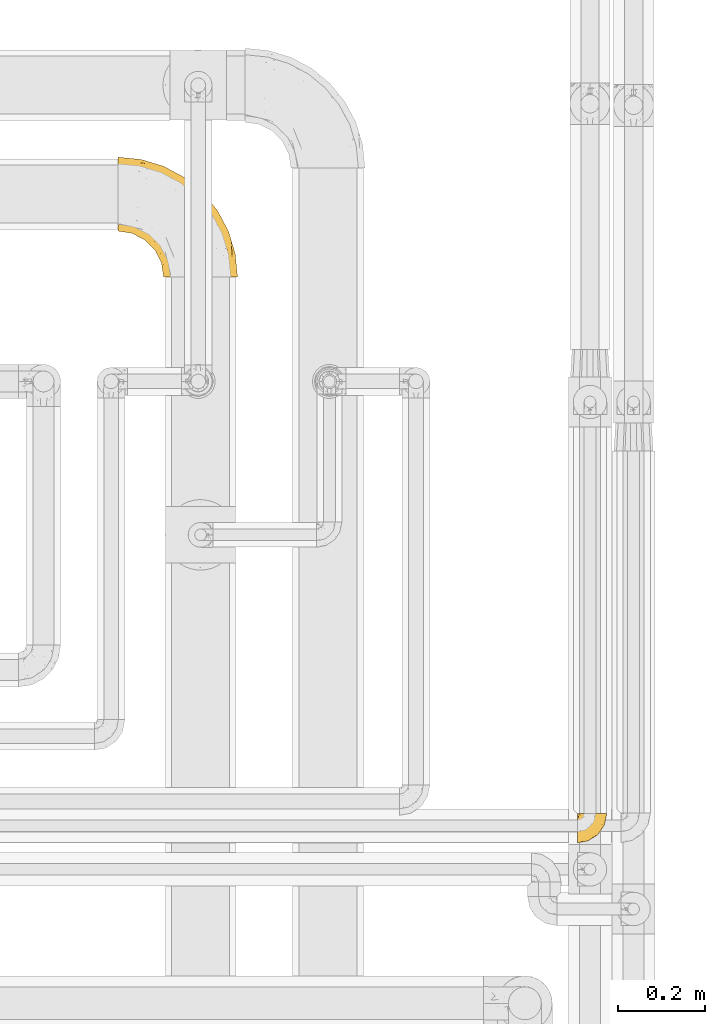
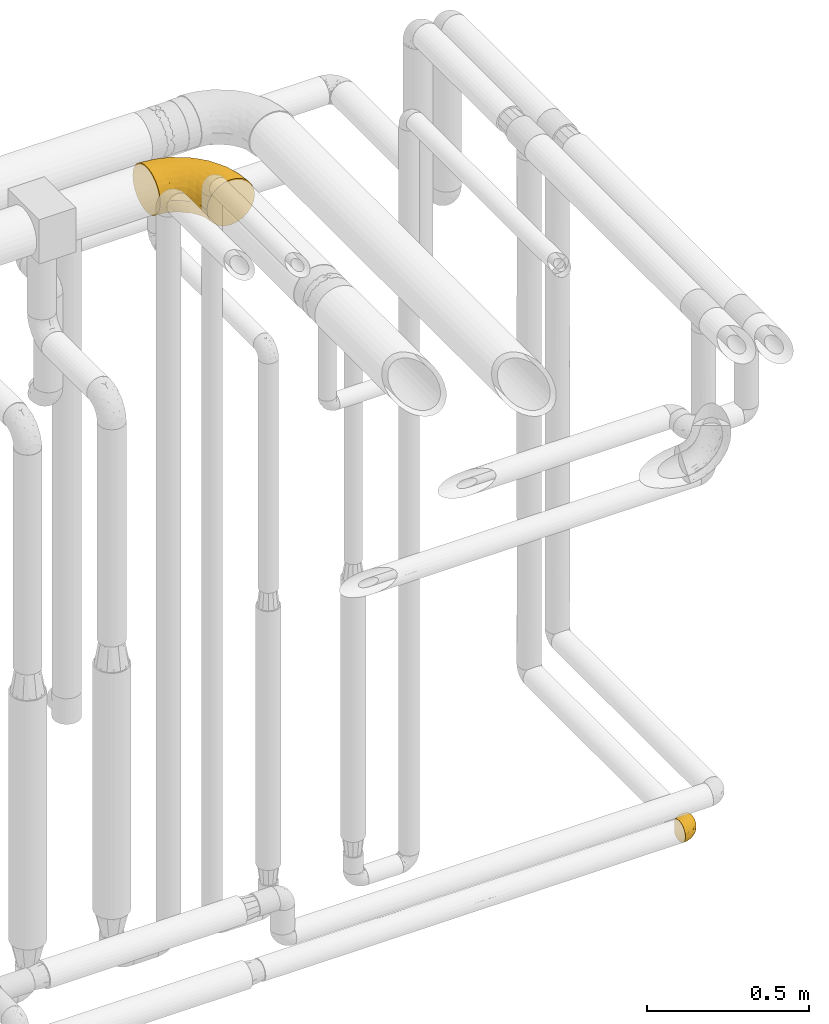
# One storey, part 500 of 827: 2 coverings.
"""IFC2X3 building model written with IfcOpenShell, lengths in millimetres."""

from ifc_helpers import new_model, entity, si_unit, converted_unit, derived_unit, direction, frame, origin, place, context, subcontext, project, spatial, faceted_brep, element, save


model = new_model("IFC2X3")

# Units and contexts
model_context = context("Model", 3, precision=0.01, world=origin(), true_north=direction((6.12303176911189e-17, 1.0)))
body_context = subcontext(model_context, "Body", "Model", "MODEL_VIEW")
ifc_project = project(units=[si_unit("LENGTHUNIT", "METRE", prefix="MILLI"), si_unit("AREAUNIT", "SQUARE_METRE"), si_unit("VOLUMEUNIT", "CUBIC_METRE"), converted_unit("PLANEANGLEUNIT", "DEGREE", entity("IfcRatioMeasure", 0.0174532925199433), si_unit("PLANEANGLEUNIT", "RADIAN"), dimensions=[0, 0, 0, 0, 0, 0, 0]), si_unit("MASSUNIT", "GRAM", prefix="KILO"), derived_unit("MASSDENSITYUNIT", [(si_unit("MASSUNIT", "GRAM", prefix="KILO"), 1), (si_unit("LENGTHUNIT", "METRE"), -3)]), derived_unit("MOMENTOFINERTIAUNIT", [(si_unit("LENGTHUNIT", "METRE"), 4)]), si_unit("TIMEUNIT", "SECOND"), si_unit("FREQUENCYUNIT", "HERTZ"), si_unit("THERMODYNAMICTEMPERATUREUNIT", "DEGREE_CELSIUS"), derived_unit("THERMALTRANSMITTANCEUNIT", [(si_unit("MASSUNIT", "GRAM", prefix="KILO"), 1), (si_unit("THERMODYNAMICTEMPERATUREUNIT", "KELVIN"), -1), (si_unit("TIMEUNIT", "SECOND"), -3)]), derived_unit("VOLUMETRICFLOWRATEUNIT", [(si_unit("LENGTHUNIT", "METRE"), 3), (si_unit("TIMEUNIT", "SECOND"), -1)]), derived_unit("MASSFLOWRATEUNIT", [(si_unit("MASSUNIT", "GRAM", prefix="KILO"), 1), (si_unit("TIMEUNIT", "SECOND"), -1)]), derived_unit("ROTATIONALFREQUENCYUNIT", [(si_unit("TIMEUNIT", "SECOND"), -1)]), si_unit("ELECTRICCURRENTUNIT", "AMPERE"), si_unit("ELECTRICVOLTAGEUNIT", "VOLT"), si_unit("POWERUNIT", "WATT"), si_unit("FORCEUNIT", "NEWTON", prefix="KILO"), si_unit("ILLUMINANCEUNIT", "LUX"), si_unit("LUMINOUSFLUXUNIT", "LUMEN"), si_unit("LUMINOUSINTENSITYUNIT", "CANDELA"), derived_unit("USERDEFINED", [(si_unit("MASSUNIT", "GRAM", prefix="KILO"), -1), (si_unit("LENGTHUNIT", "METRE"), -2), (si_unit("TIMEUNIT", "SECOND"), 3), (si_unit("LUMINOUSFLUXUNIT", "LUMEN"), 1)]), derived_unit("LINEARVELOCITYUNIT", [(si_unit("LENGTHUNIT", "METRE"), 1), (si_unit("TIMEUNIT", "SECOND"), -1)]), si_unit("PRESSUREUNIT", "PASCAL"), derived_unit("USERDEFINED", [(si_unit("LENGTHUNIT", "METRE"), -2), (si_unit("MASSUNIT", "GRAM", prefix="KILO"), 1), (si_unit("TIMEUNIT", "SECOND"), -2)]), derived_unit("LINEARFORCEUNIT", [(si_unit("MASSUNIT", "GRAM", prefix="KILO"), 1), (si_unit("LENGTHUNIT", "METRE"), 1), (si_unit("TIMEUNIT", "SECOND"), -2), (si_unit("LENGTHUNIT", "METRE"), -1)]), derived_unit("PLANARFORCEUNIT", [(si_unit("MASSUNIT", "GRAM", prefix="KILO"), 1), (si_unit("LENGTHUNIT", "METRE"), 1), (si_unit("TIMEUNIT", "SECOND"), -2), (si_unit("LENGTHUNIT", "METRE"), -2)])], contexts=[model_context])

# Site, building, storey
site_placement = place(None, origin())
site = spatial("IfcSite", under=ifc_project, at=site_placement, CompositionType="ELEMENT")
building_placement = place(site_placement, origin())
building = spatial("IfcBuilding", under=site, at=building_placement, CompositionType="ELEMENT")
storey_placement = place(building_placement, frame((0.0, 0.0, 28200.0)))
storey = spatial("IfcBuildingStorey", under=building, at=storey_placement, Name="08", CompositionType="ELEMENT", Elevation=28200.0)

# Coverings
covering_1_placement = place(storey_placement, frame((59966.95, 17738.5, 2813.52)))
element("IfcCovering", 1, at=covering_1_placement, inside=storey, Name=":ADSK_", ObjectType=":ADSK_", PredefinedType="INSULATION", context=body_context, shape_type="Brep", body=[
    faceted_brep([(1.6, 220.62, 166.18), (1.6, 234.03, 159.92), (1.6, 246.14, 151.44), (1.6, 256.6, 140.98), (1.6, 265.08, 128.87), (1.6, 271.33, 115.47), (1.6, 275.16, 101.18), (1.6, 276.45, 86.45), (1.6, 275.16, 71.71), (1.6, 271.33, 57.42), (1.6, 265.07, 44.02), (1.6, 256.59, 31.9), (1.6, 246.13, 21.44), (1.6, 234.02, 12.96), (1.6, 220.62, 6.71), (1.6, 206.33, 2.88), (1.6, 191.6, 1.6), (1.6, 176.86, 2.89), (1.6, 162.57, 6.71), (1.6, 149.17, 12.97), (1.6, 137.05, 21.45), (1.6, 126.59, 31.91), (1.6, 118.11, 44.02), (1.6, 111.86, 57.42), (1.6, 108.03, 71.71), (1.6, 106.75, 86.45), (1.6, 108.04, 101.18), (1.6, 111.86, 115.47), (1.6, 118.12, 128.88), (1.6, 126.6, 140.99), (1.6, 137.06, 151.45), (1.6, 149.17, 159.93), (1.6, 162.57, 166.18), (1.6, 176.86, 170.01), (1.6, 191.6, 171.3), (1.6, 206.33, 170.01), (131.6, 1.6, 26.45), (149.17, 1.6, 12.96), (169.63, 1.6, 4.49), (191.6, 1.6, 1.6), (213.56, 1.6, 4.49), (234.02, 1.6, 12.96), (251.59, 1.6, 26.45), (265.08, 1.6, 44.02), (273.55, 1.6, 64.48), (276.45, 1.6, 86.45), (273.55, 1.6, 108.41), (265.08, 1.6, 128.87), (251.59, 1.6, 146.44), (234.02, 1.6, 159.93), (213.56, 1.6, 168.4), (191.6, 1.6, 171.3), (169.63, 1.6, 168.4), (149.17, 1.6, 159.93), (131.6, 1.6, 146.44), (118.11, 1.6, 128.87), (109.64, 1.6, 108.41), (106.75, 1.6, 86.45), (109.64, 1.6, 64.48), (118.11, 1.6, 44.02), (262.36, 78.36, 108.89), (271.16, 55.22, 86.45), (255.52, 106.78, 86.45), (50.98, 227.56, 160.57), (172.61, 210.93, 113.84), (203.97, 166.54, 132.78), (212.76, 169.48, 115.35), (195.94, 195.94, 86.45), (169.94, 121.35, 169.66), (120.06, 150.14, 171.3), (135.1, 135.1, 171.3), (150.14, 120.06, 171.3), (237.65, 124.32, 124.06), (241.63, 130.67, 106.11), (58.66, 210.57, 167.01), (229.96, 93.72, 149.97), (211.71, 139.64, 145.0), (192.74, 144.17, 156.09), (230.12, 154.29, 86.45), (158.59, 208.4, 134.92), (110.39, 240.3, 130.81), (119.11, 221.79, 146.85), (154.29, 230.12, 86.45), (62.72, 262.33, 120.3), (111.17, 248.26, 114.99), (79.56, 263.49, 102.82), (253.1, 63.94, 135.66), (235.85, 108.29, 137.97), (195.66, 79.35, 169.13), (241.79, 42.69, 152.15), (55.22, 271.16, 86.45), (106.78, 255.52, 86.45), (217.39, 76.62, 162.08), (99.75, 212.49, 159.81), (264.19, 49.07, 122.41), (186.11, 126.68, 164.65), (153.25, 177.19, 160.16), (177.64, 177.64, 147.45), (119.88, 179.24, 168.0), (172.78, 84.03, 171.3), (84.03, 172.78, 171.3), (62.89, 246.43, 143.95), (186.83, 43.87, 171.3), (43.87, 186.83, 171.3), (113.05, 35.25, 128.7), (100.5, 55.06, 120.84), (106.86, 29.97, 111.79), (163.63, 40.1, 167.99), (25.67, 174.11, 169.81), (62.91, 141.82, 162.83), (91.14, 151.41, 169.87), (66.45, 162.23, 169.62), (106.25, 68.19, 139.83), (117.34, 78.22, 154.11), (94.43, 94.43, 147.7), (85.43, 83.32, 129.83), (32.15, 106.07, 111.24), (57.82, 95.5, 113.13), (52.87, 105.97, 128.47), (135.69, 106.13, 168.91), (127.24, 90.7, 163.29), (150.81, 84.2, 169.04), (86.66, 63.4, 86.45), (96.24, 50.79, 102.42), (78.07, 78.07, 108.81), (142.05, 30.53, 157.36), (122.04, 42.81, 143.61), (71.57, 119.66, 152.9), (88.75, 127.3, 162.78), (34.09, 101.6, 86.45), (63.4, 86.66, 86.45), (117.23, 132.44, 169.89), (43.38, 118.77, 140.27), (26.96, 113.91, 126.4), (101.6, 34.09, 86.45), (114.56, 114.56, 165.72), (38.85, 159.75, 166.71), (67.12, 108.44, 141.38), (28.1, 145.49, 159.19), (106.51, 101.13, 158.14), (36.78, 131.96, 151.08), (137.5, 64.62, 161.17), (78.07, 78.07, 64.08), (186.83, 43.87, 1.6), (163.63, 40.1, 4.9), (172.78, 84.03, 1.6), (106.86, 29.97, 61.1), (96.24, 50.79, 70.47), (25.67, 174.1, 3.08), (100.5, 55.06, 52.05), (113.05, 35.25, 44.19), (57.82, 95.5, 59.77), (85.44, 83.31, 43.07), (106.25, 68.19, 33.07), (52.86, 105.97, 44.43), (67.12, 108.44, 31.51), (142.05, 30.53, 15.53), (122.04, 42.81, 29.28), (137.5, 64.63, 11.72), (32.15, 106.07, 61.65), (150.8, 84.21, 3.85), (150.14, 120.06, 1.6), (66.45, 162.23, 3.27), (43.87, 186.83, 1.6), (84.03, 172.78, 1.6), (71.57, 119.66, 19.99), (36.79, 131.95, 21.82), (62.92, 141.81, 10.07), (26.95, 113.91, 46.49), (88.75, 127.29, 10.11), (35.6, 145.35, 12.88), (43.38, 118.77, 32.63), (127.23, 90.7, 9.6), (135.68, 106.13, 3.98), (135.1, 135.1, 1.6), (117.33, 78.22, 18.78), (38.86, 159.75, 6.18), (91.14, 151.41, 3.02), (120.06, 150.14, 1.6), (117.23, 132.44, 3.0), (114.56, 114.56, 7.17), (106.5, 101.13, 14.75), (94.43, 94.43, 25.19), (195.66, 79.35, 3.76), (169.94, 121.35, 3.23), (186.11, 126.68, 8.24), (262.36, 78.36, 64.0), (58.66, 210.57, 5.88), (99.75, 212.49, 13.07), (153.26, 177.18, 12.73), (119.88, 179.23, 4.89), (119.11, 221.79, 26.04), (212.77, 169.48, 57.54), (217.39, 76.62, 10.82), (255.51, 82.71, 49.85), (253.1, 63.94, 37.23), (235.86, 108.29, 34.92), (241.79, 42.69, 20.74), (229.96, 93.72, 22.92), (172.61, 210.93, 59.05), (111.17, 248.25, 57.9), (177.64, 177.64, 25.44), (158.58, 208.4, 37.97), (237.65, 124.32, 48.83), (241.63, 130.67, 66.78), (211.71, 139.64, 27.89), (62.72, 262.33, 52.59), (203.97, 166.55, 40.11), (62.88, 246.43, 28.94), (50.99, 227.55, 12.32), (192.75, 144.16, 16.8), (79.56, 263.49, 70.06), (110.39, 240.3, 42.07)], [[[0, 1, 2, 3, 4, 5, 6, 7, 8, 9, 10, 11, 12, 13, 14, 15, 16, 17, 18, 19, 20, 21, 22, 23, 24, 25, 26, 27, 28, 29, 30, 31, 32, 33, 34, 35]], [[36, 37, 38, 39, 40, 41, 42, 43, 44, 45, 46, 47, 48, 49, 50, 51, 52, 53, 54, 55, 56, 57, 58, 59]], [[60, 61, 62]], [[61, 46, 45]], [[63, 2, 1]], [[64, 65, 66]], [[64, 66, 67]], [[68, 69, 70, 71]], [[72, 73, 66]], [[74, 0, 35]], [[75, 76, 77]], [[78, 73, 62]], [[79, 80, 81]], [[64, 67, 82]], [[83, 84, 85]], [[86, 48, 47]], [[65, 76, 87]], [[51, 50, 88]], [[75, 89, 86]], [[90, 85, 91]], [[75, 77, 92]], [[74, 93, 63]], [[94, 46, 60]], [[95, 68, 88]], [[96, 97, 81]], [[96, 93, 98]], [[88, 68, 99]], [[98, 100, 69]], [[83, 101, 80]], [[101, 63, 81]], [[48, 89, 49]], [[79, 65, 64]], [[85, 6, 5]], [[101, 83, 3]], [[50, 92, 88]], [[83, 85, 5]], [[94, 86, 47]], [[3, 83, 4]], [[75, 87, 76]], [[90, 7, 6]], [[88, 99, 102]], [[101, 3, 2]], [[100, 98, 74]], [[100, 74, 103]], [[4, 83, 5]], [[34, 103, 35]], [[51, 88, 102]], [[85, 84, 91]], [[72, 86, 94]], [[81, 80, 101]], [[103, 74, 35]], [[98, 69, 68]], [[98, 93, 74]], [[74, 63, 0]], [[63, 101, 2]], [[50, 49, 92]], [[46, 61, 60]], [[84, 82, 91]], [[89, 92, 49]], [[95, 88, 92]], [[6, 85, 90]], [[83, 80, 84]], [[96, 81, 93]], [[79, 81, 97]], [[65, 79, 97]], [[64, 80, 79]], [[76, 65, 97]], [[65, 72, 66]], [[80, 64, 84]], [[82, 84, 64]], [[73, 72, 60]], [[67, 66, 78]], [[62, 73, 60]], [[78, 66, 73]], [[98, 95, 96]], [[77, 96, 95]], [[98, 68, 95]], [[99, 68, 71]], [[63, 93, 81]], [[0, 63, 1]], [[77, 76, 97]], [[75, 86, 87]], [[96, 77, 97]], [[77, 95, 92]], [[86, 72, 87]], [[65, 87, 72]], [[86, 89, 48]], [[92, 89, 75]], [[46, 94, 47]], [[72, 94, 60]], [[104, 105, 106]], [[52, 51, 102]], [[52, 102, 107]], [[33, 108, 103]], [[109, 110, 111]], [[112, 113, 114]], [[114, 115, 112]], [[99, 107, 102]], [[116, 117, 118]], [[119, 120, 121]], [[122, 123, 124]], [[53, 125, 54]], [[125, 126, 54]], [[127, 128, 109]], [[26, 129, 116]], [[130, 122, 124]], [[128, 131, 110]], [[57, 56, 106]], [[132, 28, 133]], [[106, 105, 123]], [[122, 134, 123]], [[135, 120, 119]], [[28, 132, 29]], [[121, 107, 99]], [[103, 108, 111]], [[107, 53, 52]], [[115, 124, 105]], [[136, 32, 31]], [[117, 129, 130]], [[34, 33, 103]], [[132, 137, 127]], [[136, 31, 138]], [[139, 114, 113]], [[32, 108, 33]], [[127, 114, 139]], [[30, 140, 138]], [[129, 26, 25]], [[133, 116, 118]], [[54, 126, 55]], [[126, 112, 104]], [[27, 26, 116]], [[116, 133, 27]], [[140, 30, 29]], [[117, 130, 124]], [[131, 119, 70]], [[109, 140, 127]], [[109, 136, 138]], [[118, 117, 115]], [[127, 140, 132]], [[110, 131, 69]], [[32, 136, 108]], [[125, 107, 141]], [[111, 108, 136]], [[105, 104, 112]], [[115, 114, 137]], [[107, 125, 53]], [[126, 125, 141]], [[105, 112, 115]], [[113, 126, 141]], [[126, 113, 112]], [[120, 113, 141]], [[134, 57, 106]], [[124, 123, 105]], [[134, 106, 123]], [[104, 56, 55]], [[56, 104, 106]], [[55, 126, 104]], [[120, 141, 121]], [[139, 120, 135]], [[107, 121, 141]], [[71, 121, 99]], [[121, 71, 119]], [[119, 71, 70]], [[131, 70, 69]], [[69, 100, 110]], [[119, 131, 135]], [[111, 110, 100]], [[110, 109, 128]], [[117, 116, 129]], [[115, 117, 124]], [[120, 139, 113]], [[139, 135, 128]], [[132, 133, 118]], [[27, 133, 28]], [[132, 118, 137]], [[29, 132, 140]], [[115, 137, 118]], [[114, 127, 137]], [[103, 111, 100]], [[109, 111, 136]], [[139, 128, 127]], [[128, 135, 131]], [[30, 138, 31]], [[109, 138, 140]], [[122, 130, 142]], [[143, 144, 145]], [[57, 134, 146]], [[146, 134, 147]], [[17, 148, 18]], [[149, 150, 146]], [[142, 149, 147]], [[122, 147, 134]], [[130, 129, 151]], [[150, 58, 146]], [[149, 152, 153]], [[154, 155, 152]], [[37, 144, 38]], [[39, 38, 143]], [[37, 36, 156]], [[156, 157, 158]], [[159, 154, 151]], [[144, 143, 38]], [[145, 160, 161]], [[36, 59, 157]], [[162, 163, 164]], [[165, 166, 167]], [[154, 159, 168]], [[162, 148, 163]], [[129, 25, 24]], [[169, 165, 167]], [[170, 20, 19]], [[168, 23, 22]], [[171, 21, 166]], [[160, 158, 172]], [[161, 173, 174]], [[165, 155, 171]], [[151, 129, 159]], [[20, 166, 21]], [[175, 172, 158]], [[170, 176, 167]], [[177, 178, 179]], [[179, 173, 180]], [[162, 164, 177]], [[152, 149, 142]], [[170, 167, 166]], [[171, 154, 168]], [[17, 16, 163]], [[129, 24, 159]], [[165, 169, 181]], [[17, 163, 148]], [[176, 19, 18]], [[153, 175, 157]], [[160, 144, 158]], [[23, 159, 24]], [[171, 155, 154]], [[156, 144, 37]], [[176, 18, 148]], [[152, 142, 151]], [[153, 152, 182]], [[157, 156, 36]], [[144, 156, 158]], [[175, 153, 182]], [[153, 157, 150]], [[181, 175, 182]], [[157, 175, 158]], [[142, 147, 122]], [[146, 147, 149]], [[153, 150, 149]], [[146, 58, 57]], [[157, 59, 150]], [[58, 150, 59]], [[181, 172, 175]], [[172, 173, 160]], [[172, 180, 173]], [[144, 160, 145]], [[179, 178, 174]], [[161, 160, 173]], [[164, 178, 177]], [[173, 179, 174]], [[169, 177, 179]], [[169, 179, 180]], [[162, 167, 176]], [[152, 151, 154]], [[130, 151, 142]], [[165, 181, 182]], [[172, 181, 180]], [[23, 168, 159]], [[22, 21, 171]], [[171, 168, 22]], [[165, 171, 166]], [[165, 182, 155]], [[152, 155, 182]], [[167, 162, 177]], [[162, 176, 148]], [[177, 169, 167]], [[181, 169, 180]], [[20, 170, 166]], [[19, 176, 170]], [[183, 184, 185]], [[43, 186, 44]], [[61, 44, 186]], [[183, 39, 143]], [[145, 161, 184]], [[62, 61, 186]], [[187, 164, 163]], [[188, 189, 190]], [[188, 191, 189]], [[178, 190, 184]], [[192, 67, 78]], [[193, 183, 185]], [[194, 43, 195]], [[195, 196, 194]], [[61, 45, 44]], [[40, 193, 41]], [[41, 197, 42]], [[197, 193, 198]], [[82, 199, 200]], [[201, 191, 202]], [[42, 197, 195]], [[203, 192, 204]], [[15, 187, 163]], [[62, 186, 204]], [[195, 43, 42]], [[190, 185, 184]], [[190, 178, 164]], [[196, 198, 205]], [[206, 10, 9]], [[205, 201, 207]], [[163, 16, 15]], [[14, 187, 15]], [[12, 208, 209]], [[39, 183, 40]], [[208, 12, 11]], [[205, 210, 201]], [[185, 210, 193]], [[13, 209, 14]], [[188, 190, 187]], [[206, 211, 200]], [[82, 67, 199]], [[208, 11, 206]], [[203, 207, 192]], [[90, 91, 211]], [[191, 188, 209]], [[206, 11, 10]], [[211, 8, 90]], [[9, 8, 211]], [[7, 90, 8]], [[191, 208, 212]], [[191, 209, 208]], [[208, 206, 212]], [[200, 212, 206]], [[145, 183, 143]], [[193, 40, 183]], [[188, 187, 209]], [[187, 190, 164]], [[202, 207, 201]], [[91, 82, 200]], [[211, 206, 9]], [[202, 191, 212]], [[189, 191, 201]], [[212, 199, 202]], [[199, 192, 207]], [[199, 207, 202]], [[195, 198, 196]], [[200, 211, 91]], [[199, 212, 200]], [[67, 192, 199]], [[204, 186, 194]], [[192, 78, 204]], [[62, 204, 78]], [[210, 189, 201]], [[185, 190, 189]], [[145, 184, 183]], [[184, 161, 174, 178]], [[14, 209, 187]], [[209, 13, 12]], [[196, 207, 203]], [[198, 193, 210]], [[198, 210, 205]], [[189, 210, 185]], [[207, 196, 205]], [[194, 196, 203]], [[193, 197, 41]], [[195, 197, 198]], [[204, 194, 203]], [[43, 194, 186]]]),
])
covering_2_placement = place(storey_placement, frame((61021.94, 16439.11, 959.96)))
element("IfcCovering", 2, at=covering_2_placement, inside=storey, Name=":ADSK_", ObjectType=":ADSK_", PredefinedType="INSULATION", context=body_context, shape_type="Brep", body=[
    faceted_brep([(47.38, 69.16, 74.68), (54.67, 69.16, 70.1), (60.76, 69.15, 64.01), (65.34, 69.15, 56.72), (68.18, 69.15, 48.6), (69.15, 69.15, 40.05), (68.18, 69.14, 31.49), (65.33, 69.14, 23.36), (60.75, 69.14, 16.07), (54.66, 69.13, 9.98), (47.37, 69.13, 5.4), (39.25, 69.13, 2.56), (30.7, 69.13, 1.6), (22.59, 69.13, 2.46), (14.86, 69.13, 5.01), (7.84, 69.13, 9.13), (1.85, 69.14, 14.62), (1.85, 69.14, 16.82), (1.85, 69.14, 18.56), (1.85, 69.14, 20.52), (1.85, 69.14, 22.49), (1.85, 69.14, 24.46), (1.85, 69.14, 26.42), (1.85, 69.14, 28.39), (1.85, 69.14, 30.36), (1.85, 69.14, 32.55), (1.85, 69.14, 34.75), (1.85, 69.14, 36.94), (1.85, 69.14, 39.13), (1.85, 69.15, 41.33), (1.85, 69.15, 43.52), (1.85, 69.15, 45.72), (1.85, 69.15, 47.91), (1.85, 69.15, 50.11), (1.85, 69.15, 52.3), (1.85, 69.15, 54.49), (1.85, 69.15, 56.69), (1.85, 69.15, 58.88), (1.85, 69.15, 61.08), (1.85, 69.15, 63.27), (1.85, 69.15, 65.47), (7.85, 69.16, 70.97), (14.88, 69.16, 75.09), (22.61, 69.16, 77.64), (30.7, 69.16, 78.5), (39.26, 69.16, 77.53), (1.6, 68.88, 14.62), (1.6, 62.88, 9.12), (1.6, 55.86, 5.01), (1.6, 48.13, 2.46), (1.6, 40.03, 1.61), (1.6, 30.08, 2.92), (1.6, 20.81, 6.76), (1.6, 12.85, 12.88), (1.6, 6.74, 20.84), (1.6, 2.9, 30.12), (1.6, 1.6, 40.07), (1.6, 2.91, 50.02), (1.6, 6.75, 59.29), (1.6, 12.87, 67.25), (1.6, 20.83, 73.36), (1.6, 30.11, 77.2), (1.6, 40.06, 78.51), (1.6, 48.15, 77.64), (1.6, 55.88, 75.09), (1.6, 62.91, 70.97), (1.6, 68.9, 65.47), (1.6, 68.9, 63.27), (1.6, 68.9, 62.29), (1.6, 68.9, 60.7), (1.6, 68.9, 59.11), (1.6, 68.9, 57.52), (1.6, 68.9, 55.93), (1.6, 68.9, 54.34), (1.6, 68.9, 52.76), (1.6, 68.9, 51.17), (1.6, 68.9, 49.58), (1.6, 68.9, 47.99), (1.6, 68.89, 46.4), (1.6, 68.89, 44.81), (1.6, 68.89, 43.22), (1.6, 68.89, 41.63), (1.6, 68.89, 40.05), (1.6, 68.89, 38.46), (1.6, 68.89, 36.87), (1.6, 68.89, 35.28), (1.6, 68.89, 33.69), (1.6, 68.89, 32.1), (1.6, 68.89, 30.51), (1.6, 68.89, 28.92), (1.6, 68.89, 27.33), (1.6, 68.89, 25.37), (1.6, 68.89, 23.4), (1.6, 68.89, 21.21), (1.6, 68.88, 19.01), (1.6, 68.88, 16.82), (1.78, 68.97, 42.32), (1.77, 68.96, 44.02), (1.78, 68.97, 47.13), (1.77, 68.97, 48.74), (1.79, 68.97, 23.57), (1.78, 68.97, 25.13), (1.76, 68.96, 61.34), (1.77, 68.95, 22.02), (1.77, 68.96, 29.72), (1.76, 68.96, 56.73), (1.77, 68.97, 55.14), (1.77, 68.96, 37.66), (1.8, 69.01, 64.12), (1.76, 68.95, 28.13), (1.77, 68.95, 26.62), (1.78, 68.97, 31.46), (1.77, 68.95, 16.16), (1.77, 68.96, 39.16), (1.76, 68.96, 50.37), (1.77, 68.96, 17.69), (1.78, 68.97, 19.17), (1.77, 68.97, 62.78), (1.77, 68.97, 58.35), (1.77, 68.96, 45.53), (1.78, 68.98, 59.91), (1.77, 68.98, 65.47), (1.8, 69.03, 65.47), (1.82, 69.09, 65.47), (1.77, 68.96, 14.62), (1.72, 68.93, 14.62), (1.66, 68.91, 14.62), (1.76, 68.95, 20.59), (1.77, 68.96, 32.99), (1.76, 68.95, 34.48), (1.77, 68.96, 51.91), (1.66, 68.93, 65.47), (1.72, 68.95, 65.47), (1.78, 68.98, 53.48), (1.82, 69.07, 14.62), (1.8, 69.01, 14.62), (1.77, 68.96, 40.77), (1.78, 68.97, 35.97), (3.72, 61.32, 7.84), (7.41, 53.08, 3.53), (6.13, 63.32, 8.32), (19.34, 55.52, 2.19), (17.64, 63.32, 3.53), (26.8, 54.58, 1.6), (8.87, 41.98, 1.61), (9.2, 57.06, 4.57), (12.79, 57.93, 3.96), (14.62, 51.55, 2.29), (7.34, 41.57, 1.61), (5.33, 61.69, 7.69), (7.7, 64.99, 8.32), (9.41, 67.01, 7.84), (28.75, 61.86, 1.6), (21.47, 49.26, 1.6), (16.15, 43.93, 1.6), (14.14, 61.19, 4.34), (29.16, 63.39, 1.6), (57.02, 33.11, 29.64), (64.92, 52.82, 27.35), (64.0, 43.3, 40.05), (11.92, 33.72, 2.41), (19.16, 36.51, 2.44), (28.65, 24.86, 9.09), (24.62, 14.16, 16.66), (15.19, 18.42, 9.56), (18.36, 28.65, 4.54), (9.2, 25.98, 4.54), (46.98, 49.24, 7.49), (50.24, 59.71, 7.49), (56.1, 55.09, 12.86), (28.97, 44.7, 2.36), (54.46, 34.14, 22.68), (21.34, 5.24, 32.92), (18.4, 6.74, 25.35), (66.44, 55.54, 40.05), (12.07, 10.46, 16.66), (45.49, 25.48, 20.01), (50.57, 35.52, 16.39), (36.04, 48.2, 3.27), (42.07, 58.7, 3.76), (62.12, 57.42, 19.59), (37.37, 34.82, 7.51), (29.39, 36.86, 4.05), (53.59, 45.0, 13.94), (58.06, 44.39, 19.59), (49.27, 23.96, 28.22), (29.63, 11.19, 24.77), (33.21, 10.56, 31.44), (40.1, 16.81, 26.22), (44.08, 17.38, 33.38), (49.36, 21.38, 40.06), (56.68, 32.34, 40.06), (15.2, 4.3, 40.07), (35.57, 20.64, 16.15), (41.7, 29.65, 12.87), (46.4, 39.59, 10.48), (41.41, 42.54, 6.5), (27.45, 6.74, 40.07), (38.4, 14.06, 40.07), (12.99, 26.85, 75.58), (21.33, 5.28, 47.4), (42.89, 18.52, 52.93), (57.04, 33.13, 50.47), (56.11, 55.11, 67.23), (62.13, 57.43, 60.5), (21.89, 20.73, 70.57), (16.62, 11.47, 63.47), (32.9, 17.7, 62.63), (46.99, 49.27, 72.61), (50.25, 59.74, 72.6), (42.08, 58.73, 76.34), (49.92, 29.73, 59.35), (15.6, 35.36, 77.77), (16.15, 43.96, 78.5), (8.87, 42.01, 78.51), (29.16, 63.42, 78.5), (13.16, 4.94, 53.18), (10.83, 17.47, 70.57), (33.8, 10.94, 48.91), (25.02, 8.92, 54.78), (64.92, 52.83, 52.75), (32.83, 29.35, 71.94), (20.56, 30.28, 75.81), (58.07, 44.41, 60.51), (21.46, 39.08, 77.87), (28.1, 43.07, 77.65), (26.8, 54.61, 78.5), (21.47, 49.28, 78.5), (51.29, 42.7, 67.24), (36.04, 48.22, 76.83), (28.75, 61.88, 78.5), (8.45, 33.46, 77.82), (41.73, 29.68, 67.24), (39.27, 38.51, 73.22), (33.56, 23.36, 67.68), (27.29, 34.99, 76.0), (7.41, 53.11, 76.57), (3.51, 59.7, 73.22), (4.68, 62.2, 71.93), (5.52, 64.12, 71.07), (8.75, 57.98, 75.09), (12.79, 57.97, 76.14), (17.65, 63.34, 76.57), (13.9, 51.79, 77.7), (9.42, 67.03, 72.26), (7.68, 64.99, 71.77), (19.33, 55.55, 77.9), (14.13, 61.23, 75.75)], [[[0, 1, 2, 3, 4, 5, 6, 7, 8, 9, 10, 11, 12, 13, 14, 15, 16, 17, 18, 19, 20, 21, 22, 23, 24, 25, 26, 27, 28, 29, 30, 31, 32, 33, 34, 35, 36, 37, 38, 39, 40, 41, 42, 43, 44, 45]], [[46, 47, 48, 49, 50, 51, 52, 53, 54, 55, 56, 57, 58, 59, 60, 61, 62, 63, 64, 65, 66, 67, 68, 69, 70, 71, 72, 73, 74, 75, 76, 77, 78, 79, 80, 81, 82, 83, 84, 85, 86, 87, 88, 89, 90, 91, 92, 93, 94, 95]], [[96, 97, 30]], [[98, 77, 99]], [[100, 101, 21]], [[69, 68, 102]], [[20, 19, 103]], [[24, 23, 104]], [[20, 103, 100]], [[72, 105, 106]], [[84, 83, 107]], [[89, 88, 104]], [[108, 67, 66]], [[109, 110, 90]], [[111, 25, 24]], [[112, 17, 16]], [[82, 113, 83]], [[109, 23, 22]], [[114, 76, 75]], [[105, 36, 106]], [[104, 111, 24]], [[18, 115, 116]], [[97, 96, 80]], [[67, 108, 117]], [[105, 71, 118]], [[31, 97, 119]], [[102, 120, 69]], [[108, 121, 122, 123, 40]], [[112, 95, 115]], [[17, 115, 18]], [[94, 116, 115]], [[117, 68, 67]], [[38, 117, 39]], [[112, 124, 125, 126, 46]], [[17, 112, 115]], [[70, 120, 118]], [[39, 117, 108]], [[120, 38, 37]], [[120, 37, 118]], [[120, 70, 69]], [[116, 94, 127]], [[128, 86, 129]], [[117, 38, 102]], [[74, 130, 75]], [[99, 33, 32]], [[115, 95, 94]], [[39, 108, 40]], [[108, 66, 131, 132, 121]], [[105, 72, 71]], [[118, 37, 36]], [[71, 70, 118]], [[35, 106, 36]], [[36, 105, 118]], [[35, 133, 106]], [[74, 73, 133]], [[106, 133, 73]], [[99, 114, 33]], [[133, 35, 34]], [[73, 72, 106]], [[95, 112, 46]], [[112, 16, 134, 135, 124]], [[130, 114, 75]], [[99, 76, 114]], [[114, 130, 33]], [[34, 33, 130]], [[78, 77, 98]], [[98, 119, 78]], [[130, 133, 34]], [[133, 130, 74]], [[79, 97, 80]], [[98, 99, 32]], [[98, 32, 31]], [[77, 76, 99]], [[97, 79, 119]], [[136, 96, 29]], [[30, 97, 31]], [[136, 29, 28]], [[81, 80, 96]], [[29, 96, 30]], [[31, 119, 98]], [[119, 79, 78]], [[96, 136, 81]], [[82, 81, 136]], [[113, 107, 83]], [[84, 107, 137]], [[107, 27, 137]], [[113, 28, 107]], [[27, 107, 28]], [[85, 84, 137]], [[137, 27, 26]], [[113, 136, 28]], [[136, 113, 82]], [[109, 89, 104]], [[86, 85, 129]], [[89, 109, 90]], [[111, 87, 128]], [[26, 129, 137]], [[88, 111, 104]], [[25, 111, 128]], [[22, 110, 109]], [[23, 109, 104]], [[110, 91, 90]], [[100, 92, 101]], [[110, 22, 101]], [[91, 110, 101]], [[116, 19, 18]], [[111, 88, 87]], [[127, 103, 19]], [[25, 128, 26]], [[86, 128, 87]], [[128, 129, 26]], [[137, 129, 85]], [[120, 102, 38]], [[117, 102, 68]], [[91, 101, 92]], [[21, 101, 22]], [[93, 92, 103]], [[100, 21, 20]], [[100, 103, 92]], [[127, 93, 103]], [[93, 127, 94]], [[116, 127, 19]], [[126, 138, 47]], [[48, 138, 139]], [[140, 125, 124]], [[141, 142, 143]], [[144, 49, 139]], [[145, 140, 146]], [[48, 139, 49]], [[139, 145, 147]], [[49, 144, 148, 50]], [[126, 125, 149]], [[14, 13, 142]], [[150, 146, 140]], [[149, 140, 145]], [[151, 150, 135]], [[151, 14, 142]], [[16, 15, 134]], [[13, 152, 142]], [[124, 150, 140]], [[141, 143, 153]], [[14, 151, 15]], [[15, 151, 134]], [[47, 46, 126]], [[139, 154, 144]], [[138, 48, 47]], [[125, 140, 149]], [[135, 134, 151]], [[146, 155, 141]], [[145, 146, 147]], [[149, 139, 138]], [[147, 153, 154]], [[147, 146, 141]], [[139, 147, 154]], [[139, 149, 145]], [[149, 138, 126]], [[147, 141, 153]], [[146, 150, 155]], [[151, 155, 150]], [[142, 141, 155]], [[13, 12, 156, 152]], [[152, 143, 142]], [[151, 142, 155]], [[150, 124, 135]], [[157, 158, 159]], [[160, 154, 161]], [[162, 163, 164]], [[165, 166, 160]], [[167, 168, 169]], [[153, 170, 161]], [[156, 12, 11]], [[158, 157, 171]], [[172, 55, 173]], [[158, 6, 174]], [[175, 54, 53]], [[52, 166, 164]], [[52, 164, 53]], [[54, 175, 173]], [[166, 52, 51]], [[176, 177, 171]], [[178, 143, 179]], [[156, 11, 179]], [[8, 7, 180]], [[169, 9, 8]], [[179, 143, 152, 156]], [[179, 11, 10]], [[168, 179, 10]], [[181, 162, 182]], [[179, 167, 178]], [[183, 184, 177]], [[183, 169, 184]], [[176, 171, 185]], [[172, 186, 187]], [[158, 7, 6]], [[159, 158, 174]], [[184, 180, 158]], [[54, 173, 55]], [[180, 169, 8]], [[188, 189, 187]], [[9, 168, 10]], [[186, 188, 187]], [[190, 157, 159, 191]], [[55, 172, 192]], [[176, 193, 194]], [[161, 170, 182]], [[162, 164, 165]], [[175, 164, 163]], [[51, 50, 148]], [[167, 195, 196]], [[178, 182, 170]], [[6, 5, 174]], [[158, 180, 7]], [[169, 180, 184]], [[169, 168, 9]], [[179, 168, 167]], [[182, 162, 165]], [[162, 194, 193]], [[161, 165, 160]], [[195, 181, 196]], [[192, 172, 197]], [[192, 56, 55]], [[189, 190, 198]], [[198, 197, 187]], [[172, 187, 197]], [[185, 189, 188]], [[198, 187, 189]], [[186, 172, 173]], [[173, 163, 186]], [[193, 186, 163]], [[176, 185, 188]], [[185, 157, 190]], [[188, 186, 193]], [[177, 176, 194]], [[188, 193, 176]], [[162, 193, 163]], [[195, 177, 194]], [[171, 177, 184]], [[181, 195, 194]], [[183, 167, 169]], [[162, 181, 194]], [[196, 182, 178]], [[158, 171, 184]], [[171, 157, 185]], [[177, 195, 183]], [[167, 183, 195]], [[182, 196, 181]], [[178, 170, 143]], [[178, 167, 196]], [[164, 175, 53]], [[173, 175, 163]], [[160, 51, 148]], [[164, 166, 165]], [[51, 160, 166]], [[160, 148, 144, 154]], [[153, 161, 154]], [[182, 165, 161]], [[190, 189, 185]], [[143, 170, 153]], [[60, 199, 61]], [[197, 200, 192]], [[201, 190, 202]], [[200, 57, 192]], [[203, 204, 2]], [[205, 206, 207]], [[208, 209, 210]], [[211, 207, 201]], [[212, 213, 214]], [[45, 215, 210]], [[216, 206, 58]], [[45, 44, 215]], [[59, 217, 60]], [[60, 217, 199]], [[0, 45, 210]], [[218, 201, 219]], [[202, 159, 220]], [[205, 221, 222]], [[223, 204, 203]], [[1, 203, 2]], [[57, 200, 216]], [[220, 3, 204]], [[220, 174, 4]], [[1, 0, 209]], [[212, 224, 213]], [[225, 226, 227]], [[228, 223, 203]], [[208, 210, 229]], [[210, 226, 229]], [[3, 220, 4]], [[58, 206, 59]], [[209, 203, 1]], [[202, 220, 223]], [[228, 203, 208]], [[202, 211, 201]], [[3, 2, 204]], [[202, 190, 191, 159]], [[210, 215, 230, 226]], [[199, 212, 231]], [[232, 233, 221]], [[233, 208, 229]], [[207, 206, 219]], [[217, 206, 205]], [[227, 224, 225]], [[233, 232, 228]], [[201, 207, 219]], [[234, 232, 221]], [[218, 219, 200]], [[202, 223, 211]], [[174, 220, 159]], [[174, 5, 4]], [[61, 231, 62]], [[220, 204, 223]], [[210, 209, 0]], [[203, 209, 208]], [[225, 233, 229]], [[224, 227, 213]], [[221, 233, 235]], [[57, 56, 192]], [[198, 218, 197]], [[200, 219, 216]], [[201, 198, 190]], [[197, 218, 200]], [[198, 201, 218]], [[206, 216, 219]], [[58, 57, 216]], [[231, 212, 214]], [[222, 212, 199]], [[228, 211, 223]], [[207, 211, 232]], [[62, 231, 214]], [[199, 231, 61]], [[233, 228, 208]], [[211, 228, 232]], [[222, 221, 235]], [[234, 205, 207]], [[206, 217, 59]], [[199, 217, 205]], [[205, 222, 199]], [[224, 222, 235]], [[222, 224, 212]], [[224, 235, 225]], [[233, 225, 235]], [[226, 225, 229]], [[205, 234, 221]], [[207, 232, 234]], [[63, 214, 236]], [[214, 213, 236]], [[214, 63, 62]], [[237, 236, 238]], [[238, 132, 131]], [[236, 237, 64]], [[239, 240, 241]], [[63, 236, 64]], [[131, 66, 65]], [[237, 131, 65]], [[242, 230, 43]], [[237, 65, 64]], [[239, 121, 132]], [[42, 242, 43]], [[241, 240, 243]], [[41, 123, 244]], [[43, 230, 215, 44]], [[244, 122, 245]], [[227, 246, 243]], [[241, 247, 245]], [[121, 239, 245]], [[41, 40, 123]], [[132, 238, 239]], [[244, 42, 41]], [[131, 237, 238]], [[240, 239, 238]], [[245, 239, 241]], [[247, 241, 246]], [[247, 244, 245]], [[238, 236, 240]], [[243, 236, 213]], [[236, 243, 240]], [[227, 226, 246]], [[243, 213, 227]], [[242, 246, 226]], [[243, 246, 241]], [[246, 242, 247]], [[244, 247, 242]], [[242, 226, 230]], [[42, 244, 242]], [[122, 244, 123]], [[122, 121, 245]]]),
])

save(model, "model.ifc")
